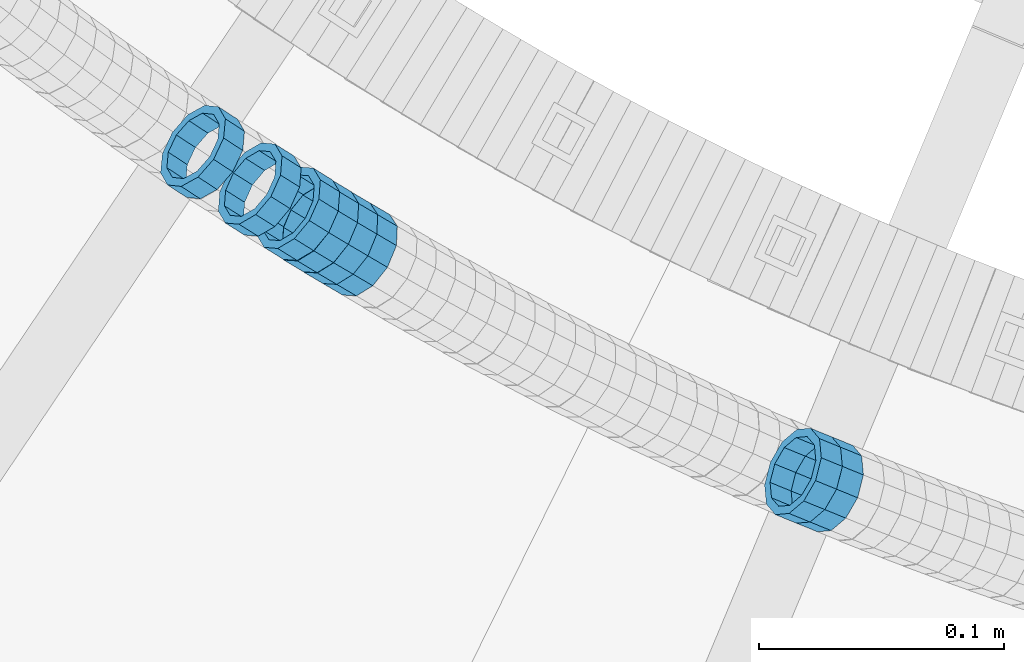
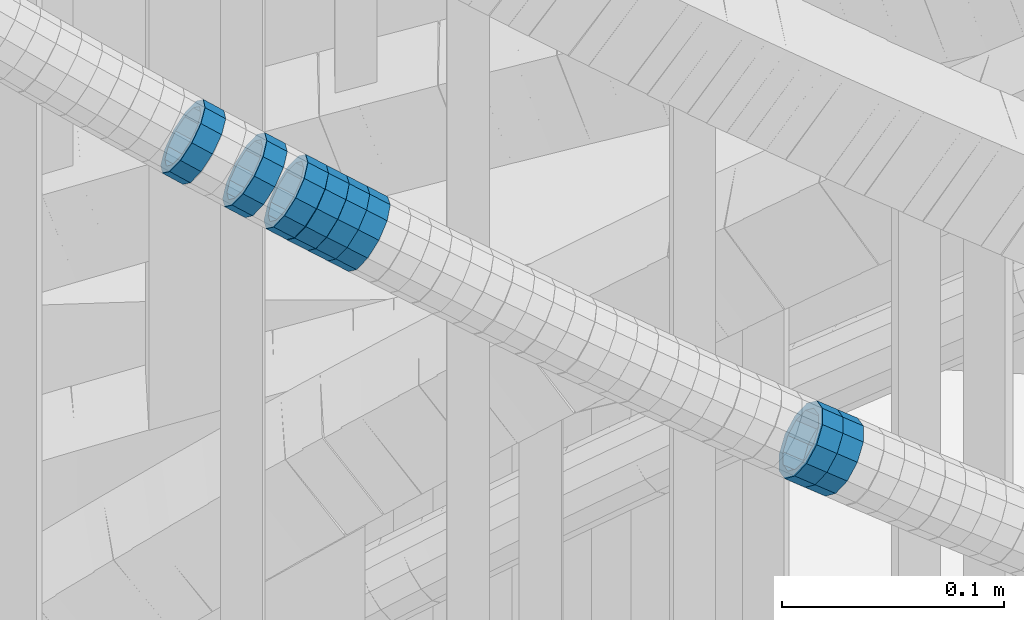
# One storey, part 693 of 975: 8 members.
"""IFC2X3 building model written with IfcOpenShell, lengths in millimetres."""

import ifcopenshell
import ifcopenshell.guid

model = None  # the IFC model being written
_history = None  # IfcOwnerHistory: only IFC2X3 demands one
_inside = {}  # id of a spatial element -> (the spatial element, [elements in it])
_under = {}  # id of a project, library or spatial element -> (it, [spatial elements below it])
_declared = {}  # id of a project -> (the project, [libraries it declares])
_typed = {}  # id of a type object -> (the type object, [elements of that type])
_made_of = {}  # id of a material, layer set ... -> (it, [elements and type objects made of it])


def new_model(schema):
    """Start an empty IFC model of exactly this schema.

    Asked for "IFC4X3", IfcOpenShell would pick the latest addendum, in which some entities
    have other attributes; the version numbers below select the first issue.
    IFC2X3 requires an IfcOwnerHistory on every rooted entity: one is made here for all.
    """
    global model, _history
    if schema == "IFC4X3":
        model = ifcopenshell.file(schema_version=(4, 3, 0, 0))
    else:
        model = ifcopenshell.file(schema=schema)
    _inside.clear()
    _under.clear()
    _declared.clear()
    _typed.clear()
    _made_of.clear()
    _history = None
    if model.schema == "IFC2X3":
        org = make("IfcOrganization", Name="unknown")
        user = make(
            "IfcPersonAndOrganization",
            ThePerson=make("IfcPerson", FamilyName="unknown"),
            TheOrganization=org,
        )
        app = make(
            "IfcApplication",
            ApplicationDeveloper=org,
            Version="unknown",
            ApplicationFullName="unknown",
            ApplicationIdentifier="unknown",
        )
        _history = make(
            "IfcOwnerHistory",
            OwningUser=user,
            OwningApplication=app,
            ChangeAction="ADDED",
            CreationDate=0,
        )
    return model


def make(cls, **values):
    """One entity of the class cls with the attributes given. An attribute that is None is left unset."""
    return model.create_entity(
        cls, **{name: value for name, value in values.items() if value is not None}
    )


def rooted(cls, **values):
    """An entity with a GlobalId (a new one), such as an element, a storey or a relation."""
    return make(cls, GlobalId=ifcopenshell.guid.new(), OwnerHistory=_history, **values)


def si_unit(unit_type, name, prefix=None):
    """IfcSIUnit, for example si_unit("LENGTHUNIT", "METRE", prefix="MILLI")."""
    return make("IfcSIUnit", UnitType=unit_type, Prefix=prefix, Name=name)


def assignment(units):
    """IfcUnitAssignment: the units of a project."""
    return None if units is None else make("IfcUnitAssignment", Units=units)


def point(xyz):
    """IfcCartesianPoint."""
    return None if xyz is None else make("IfcCartesianPoint", Coordinates=xyz)


def direction(xyz):
    """IfcDirection."""
    return None if xyz is None else make("IfcDirection", DirectionRatios=xyz)


def frame(location, z_axis=None, x_axis=None):
    """IfcAxis2Placement3D, a coordinate frame: its origin and axes. An axis left out is left unset."""
    return make(
        "IfcAxis2Placement3D",
        Location=point(location),
        Axis=direction(z_axis),
        RefDirection=direction(x_axis),
    )


def origin_with_axes():
    """The frame at (0, 0, 0) with the z axis (0, 0, 1) and the x axis (1, 0, 0) written out."""
    return frame((0.0, 0.0, 0.0), z_axis=(0.0, 0.0, 1.0), x_axis=(1.0, 0.0, 0.0))


def place(relative_to, where):
    """IfcLocalPlacement: puts the frame where relative to a parent placement (None: the world)."""
    return make(
        "IfcLocalPlacement", PlacementRelTo=relative_to, RelativePlacement=where
    )


def context(
    kind, dimensions, precision=None, world=None, true_north=None, identifier=None
):
    """IfcGeometricRepresentationContext, for example the 3D "Model" context."""
    return make(
        "IfcGeometricRepresentationContext",
        ContextIdentifier=identifier,
        ContextType=kind,
        CoordinateSpaceDimension=dimensions,
        Precision=precision,
        WorldCoordinateSystem=world,
        TrueNorth=true_north,
    )


def subcontext(parent, identifier, kind, view, scale=None):
    """IfcGeometricRepresentationSubContext, for example "Body" below "Model"."""
    return make(
        "IfcGeometricRepresentationSubContext",
        ContextIdentifier=identifier,
        ContextType=kind,
        ParentContext=parent,
        TargetScale=scale,
        TargetView=view,
    )


def project(units=None, contexts=None):
    """IfcProject with its units and contexts."""
    return rooted(
        "IfcProject",
        Name="project",
        RepresentationContexts=contexts,
        UnitsInContext=assignment(units),
    )


def spatial(cls, under=None, at=None, **own):
    """A site, building, storey or space (cls), placed at a placement, below another one or the project."""
    s = rooted(cls, ObjectPlacement=at, **own)
    if under is not None:
        _under.setdefault(under.id(), (under, []))[1].append(s)
    return s


def faces_of(points, faces, orient=None, outer=None):
    """IfcFace entities. A face is a list of loops; a loop is a list of indices into points, from 0.

    orient and outer hold one flag for each loop. By default every Orientation is true, the
    first loop of a face is its IfcFaceOuterBound and the others are IfcFaceBound.
    """
    made = []
    for i, loops in enumerate(faces):
        bounds = []
        for j, loop in enumerate(loops):
            is_outer = j == 0 if outer is None else outer[i][j]
            bounds.append(
                make(
                    "IfcFaceOuterBound" if is_outer else "IfcFaceBound",
                    Bound=make("IfcPolyLoop", Polygon=[points[k] for k in loop]),
                    Orientation=True if orient is None else orient[i][j],
                )
            )
        made.append(make("IfcFace", Bounds=bounds))
    return made


def faceted_brep(points, faces, orient=None, outer=None, voids=None):
    """IfcFacetedBrep: a solid bounded by flat faces; with voids (closed shells), ...WithVoids."""
    shared = [point(p) for p in points]
    hull = make("IfcClosedShell", CfsFaces=faces_of(shared, faces, orient, outer))
    if voids is None:
        return make("IfcFacetedBrep", Outer=hull)
    return make(
        "IfcFacetedBrepWithVoids",
        Outer=hull,
        Voids=[
            make(cls, CfsFaces=faces_of(shared, fs, o, b)) for cls, fs, o, b in voids
        ],
    )


def shape(context_of_items, identifier, shape_type, items):
    """IfcShapeRepresentation: the items that make up one representation, for example the "Body"."""
    return make(
        "IfcShapeRepresentation",
        ContextOfItems=context_of_items,
        RepresentationIdentifier=identifier,
        RepresentationType=shape_type,
        Items=items,
    )


def material(Name=None, Category=None):
    """IfcMaterial."""
    return make("IfcMaterial", Name=Name, Category=Category)


def made_of(thing, what):
    """Note that an element or type object is made of a material, layer set ...; save() writes the relation."""
    if what is not None:
        _made_of.setdefault(what.id(), (what, []))[1].append(thing)
    return thing


def type_object(cls, material=None, **own):
    """A type object (cls), such as IfcWallType, which elements share."""
    return made_of(rooted(cls, **own), material)


def element(
    cls,
    number,
    at=None,
    inside=None,
    cuts=None,
    type_object=None,
    material=None,
    context=None,
    identifier="Body",
    shape_type=None,
    held_by="IfcProductDefinitionShape",
    body=None,
    shapes=None,
    **own,
):
    """One element of the class cls, such as IfcWall. Its Tag is "e" and its number.

    at: its placement. inside: the storey or other place that contains it. cuts: it is an
    opening in that element (IfcRelVoidsElement). A single representation is given by context,
    identifier, shape_type and body (its items); several are given by shapes. held_by: the class
    of the entity that holds the representations. save() writes the other relations.
    """
    e = rooted(cls, Tag="e%d" % number, ObjectPlacement=at, **own)
    if body is not None:
        shapes = [shape(context, identifier, shape_type, body)]
    if shapes is not None:
        e.Representation = make(held_by, Representations=shapes)
    if inside is not None:
        _inside.setdefault(inside.id(), (inside, []))[1].append(e)
    if cuts is not None:
        rooted(
            "IfcRelVoidsElement", RelatingBuildingElement=cuts, RelatedOpeningElement=e
        )
    if type_object is not None:
        _typed.setdefault(type_object.id(), (type_object, []))[1].append(e)
    return made_of(e, material)


def aggregate(whole, parts):
    """IfcRelAggregates: a whole, such as a stair, and the parts it consists of."""
    return rooted("IfcRelAggregates", RelatingObject=whole, RelatedObjects=parts)


def save(model, path):
    """Write the relations noted so far, then the file.

    IfcRelAggregates (storeys below a building ...), IfcRelContainedInSpatialStructure (elements
    in a storey), IfcRelDefinesByType, IfcRelAssociatesMaterial and IfcRelDeclares: one each for
    every whole, place, type object, material and project.
    """
    for whole, parts in _under.values():
        aggregate(whole, parts)
    for where, things in _inside.values():
        rooted(
            "IfcRelContainedInSpatialStructure",
            RelatedElements=things,
            RelatingStructure=where,
        )
    for kind, things in _typed.values():
        rooted("IfcRelDefinesByType", RelatedObjects=things, RelatingType=kind)
    for what, things in _made_of.values():
        rooted("IfcRelAssociatesMaterial", RelatedObjects=things, RelatingMaterial=what)
    for by, libraries in _declared.values():
        rooted("IfcRelDeclares", RelatingContext=by, RelatedDefinitions=libraries)
    model.write(path)


model = new_model("IFC2X3")

# Units and contexts
model_context = context("Model", 3, precision=1e-05, world=origin_with_axes())
body_context = subcontext(model_context, "Body", "Model", "MODEL_VIEW")
ifc_project = project(units=[si_unit("LENGTHUNIT", "METRE", prefix="MILLI"), si_unit("AREAUNIT", "SQUARE_METRE"), si_unit("VOLUMEUNIT", "CUBIC_METRE"), si_unit("MASSUNIT", "GRAM", prefix="KILO"), si_unit("TIMEUNIT", "SECOND"), si_unit("PLANEANGLEUNIT", "RADIAN"), si_unit("SOLIDANGLEUNIT", "STERADIAN"), si_unit("THERMODYNAMICTEMPERATUREUNIT", "DEGREE_CELSIUS"), si_unit("LUMINOUSINTENSITYUNIT", "LUMEN")], contexts=[model_context])

# Site, building, storey
site_placement = place(None, origin_with_axes())
site = spatial("IfcSite", under=ifc_project, at=site_placement, CompositionType="ELEMENT")
building_placement = place(site_placement, origin_with_axes())
building = spatial("IfcBuilding", under=site, at=building_placement, Name="Undefined", CompositionType="ELEMENT")
storey_placement = place(building_placement, origin_with_axes())
storey = spatial("IfcBuildingStorey", under=building, at=storey_placement, Name="Undefined", CompositionType="ELEMENT", Elevation=0.0)

# Members
ifc_material = material()
member_type = type_object("IfcMemberType", PredefinedType="NOTDEFINED")
member_1_placement = place(storey_placement, frame((33980.090284049, 2130.72236019374, 4695.14638078626), z_axis=(-0.506549048880574, -0.862211146459025, 1.05085746326949e-10), x_axis=(-0.73111971628971, 0.429532833170209, 0.530061794210098)))
element("IfcMember", 1, at=member_1_placement, inside=storey, type_object=member_type, material=ifc_material, Name="WALL", context=body_context, shape_type="Brep", body=[
    faceted_brep([(-2.1246523829177e-07, -15.367000000002, 0.0), (-1.83998054126278e-07, -13.3082123799541, 7.68350000000009), (10.9448618081915, -13.3082123799541, 7.68349999999987), (10.944861808206, -15.3669999999875, -1.81898940354586e-12), (-1.06232619145885e-07, -7.68349999999919, 13.3082123799559), (10.9448618081733, -7.68350000000282, 13.3082123799568), (-3.63797880709171e-12, 3.63797880709171e-12, 15.3670000000002), (10.944861808166, -1.09139364212751e-11, 15.3670000000025), (1.06225343188271e-07, 7.68350000000646, 13.3082123799559), (10.9448618081624, 7.68349999998827, 13.3082123799586), (1.8399441614747e-07, 13.308212379965, 7.68350000000009), (10.9448618081697, 13.3082123799468, 7.68350000000214), (2.12461600312963e-07, 15.3670000000093, 0.0), (10.9448618081842, 15.3669999999984, 2.27373675443232e-13), (1.8399441614747e-07, 13.308212379965, -7.68350000000009), (10.9448618082024, 13.3082123799613, -7.68350000000123), (1.06225343188271e-07, 7.68350000000646, -13.3082123799559), (10.944861808217, 7.68350000001374, -13.3082123799586), (-3.63797880709171e-12, 3.63797880709171e-12, -15.3670000000002), (10.9448618082242, 1.45519152283669e-11, -15.3670000000036), (-1.06232619145885e-07, -7.68349999999919, -13.3082123799559), (10.9448618082279, -7.68349999997736, -13.30821237996), (-1.83998054126278e-07, -13.3082123799541, -7.68350000000009), (10.9448618082242, -13.3082123799322, -7.68350000000351), (-2.63386027654633e-07, -19.0500000000029, 0.0), (-2.28097633225843e-07, -16.4977839420972, -9.52499999999964), (10.9448618082242, -16.4977839420681, -9.52500000000418), (10.9448618082097, -19.0499999999847, -2.50111042987555e-12), (-1.31691194837913e-07, -9.52500000000146, -16.4977839420935), (10.9448618082351, -9.52499999997599, -16.4977839420985), (-3.63797880709171e-12, 3.63797880709171e-12, -19.0500000000002), (10.9448618082315, 2.5465851649642e-11, -19.050000000004), (1.31687556859106e-07, 9.52500000000509, -16.4977839420935), (10.9448618082242, 9.52500000001601, -16.4977839420967), (2.28097633225843e-07, 16.4977839421044, -9.52499999999964), (10.9448618082097, 16.4977839421008, -9.52500000000146), (2.63382389675826e-07, 19.0500000000138, 0.0), (10.9448618081842, 19.049999999992, 1.13686837721616e-12), (2.28097633225843e-07, 16.4977839421044, 9.52499999999964), (10.944861808166, 16.4977839420826, 9.52500000000259), (1.31687556859106e-07, 9.52500000000509, 16.4977839420935), (10.9448618081624, 9.52499999998327, 16.4977839420972), (-3.63797880709171e-12, 3.63797880709171e-12, 19.0500000000002), (10.9448618081587, -1.09139364212751e-11, 19.0500000000031), (-1.31691194837913e-07, -9.52500000000146, 16.4977839420935), (10.9448618081697, -9.52500000000873, 16.4977839420953), (-2.28097633225843e-07, -16.4977839420972, 9.52499999999964), (10.9448618081915, -16.4977839420899, 9.52499999999941)], [[[0, 1, 2, 3]], [[1, 4, 5, 2]], [[4, 6, 7, 5]], [[6, 8, 9, 7]], [[8, 10, 11, 9]], [[10, 12, 13, 11]], [[12, 14, 15, 13]], [[14, 16, 17, 15]], [[16, 18, 19, 17]], [[18, 20, 21, 19]], [[20, 22, 23, 21]], [[22, 0, 3, 23]], [[24, 25, 26, 27]], [[25, 28, 29, 26]], [[28, 30, 31, 29]], [[30, 32, 33, 31]], [[32, 34, 35, 33]], [[34, 36, 37, 35]], [[36, 38, 39, 37]], [[38, 40, 41, 39]], [[40, 42, 43, 41]], [[42, 44, 45, 43]], [[44, 46, 47, 45]], [[46, 24, 27, 47]], [[29, 31, 33, 35, 37, 39, 41, 43, 45, 47, 27, 26], [5, 7, 9, 11, 13, 15, 17, 19, 21, 23, 3, 2]], [[46, 44, 42, 40, 38, 36, 34, 32, 30, 28, 25, 24], [22, 20, 18, 16, 14, 12, 10, 8, 6, 4, 1, 0]]]),
])
member_2_placement = place(storey_placement, frame((33917.171861145, 2170.1158835901, 4740.92648604226), z_axis=(-0.547249362822599, -0.836969614078229, -1.1905467545148e-10), x_axis=(-0.710590014914603, 0.464616547944192, 0.528387446936513)))
element("IfcMember", 2, at=member_2_placement, inside=storey, type_object=member_type, material=ifc_material, Name="WALL", context=body_context, shape_type="Brep", body=[
    faceted_brep([(-2.1246523829177e-07, -15.367000000002, 0.0), (-1.83998054126278e-07, -13.3082123799541, 7.68350000000009), (10.9799817850508, -13.3082123799686, 7.6835000000051), (10.9799817850435, -15.3670000000202, 5.45696821063757e-12), (-1.06232619145885e-07, -7.68349999999919, 13.3082123799559), (10.9799817850653, -7.68350000000282, 13.3082123799577), (-3.63797880709171e-12, 3.63797880709171e-12, 15.3670000000002), (10.9799817850871, 1.45519152283669e-11, 15.3669999999984), (1.06225343188271e-07, 7.68350000000646, 13.3082123799559), (10.9799817851053, 7.68350000002465, 13.3082123799504), (1.8399441614747e-07, 13.308212379965, 7.68350000000009), (10.9799817851163, 13.3082123799904, 7.68349999999191), (2.12461600312963e-07, 15.3670000000093, 0.0), (10.9799817851199, 15.3670000000347, -9.09494701772928e-12), (1.8399441614747e-07, 13.308212379965, -7.68350000000009), (10.9799817851126, 13.3082123799832, -7.68350000000783), (1.06225343188271e-07, 7.68350000000646, -13.3082123799559), (10.9799817850981, 7.68350000001737, -13.3082123799613), (-3.63797880709171e-12, 3.63797880709171e-12, -15.3670000000002), (10.9799817850799, 3.63797880709171e-12, -15.367000000002), (-1.06232619145885e-07, -7.68349999999919, -13.3082123799559), (10.9799817850653, -7.68350000000646, -13.308212379955), (-1.83998054126278e-07, -13.3082123799541, -7.68350000000009), (10.9799817850508, -13.3082123799722, -7.68349999999509), (-2.63386027654633e-07, -19.0500000000029, 0.0), (-2.28097633225843e-07, -16.4977839420972, -9.52499999999964), (10.9799817850399, -16.4977839421153, -9.52499999999418), (10.9799817850362, -19.0500000000247, 6.3664629124105e-12), (-1.31691194837913e-07, -9.52500000000146, -16.4977839420935), (10.979981785058, -9.52500000001237, -16.4977839420912), (-3.63797880709171e-12, 3.63797880709171e-12, -19.0500000000002), (10.9799817850799, 0.0, -19.050000000002), (1.31687556859106e-07, 9.52500000000509, -16.4977839420935), (10.9799817851017, 9.52500000001965, -16.4977839420999), (2.28097633225843e-07, 16.4977839421044, -9.52499999999964), (10.9799817851235, 16.4977839421299, -9.5250000000101), (2.63382389675826e-07, 19.0500000000138, 0.0), (10.9799817851308, 19.0500000000393, -1.09139364212751e-11), (2.28097633225843e-07, 16.4977839421044, 9.52499999999964), (10.9799817851235, 16.4977839421335, 9.52499999999054), (1.31687556859106e-07, 9.52500000000509, 16.4977839420935), (10.979981785109, 9.52500000003056, 16.4977839420881), (-3.63797880709171e-12, 3.63797880709171e-12, 19.0500000000002), (10.9799817850871, 1.45519152283669e-11, 19.0499999999984), (-1.31691194837913e-07, -9.52500000000146, 16.4977839420935), (10.9799817850617, -9.52500000000509, 16.4977839420962), (-2.28097633225843e-07, -16.4977839420972, 9.52499999999964), (10.9799817850435, -16.4977839421117, 9.52500000000691)], [[[0, 1, 2, 3]], [[1, 4, 5, 2]], [[4, 6, 7, 5]], [[6, 8, 9, 7]], [[8, 10, 11, 9]], [[10, 12, 13, 11]], [[12, 14, 15, 13]], [[14, 16, 17, 15]], [[16, 18, 19, 17]], [[18, 20, 21, 19]], [[20, 22, 23, 21]], [[22, 0, 3, 23]], [[24, 25, 26, 27]], [[25, 28, 29, 26]], [[28, 30, 31, 29]], [[30, 32, 33, 31]], [[32, 34, 35, 33]], [[34, 36, 37, 35]], [[36, 38, 39, 37]], [[38, 40, 41, 39]], [[40, 42, 43, 41]], [[42, 44, 45, 43]], [[44, 46, 47, 45]], [[46, 24, 27, 47]], [[29, 31, 33, 35, 37, 39, 41, 43, 45, 47, 27, 26], [5, 7, 9, 11, 13, 15, 17, 19, 21, 23, 3, 2]], [[46, 44, 42, 40, 38, 36, 34, 32, 30, 28, 25, 24], [22, 20, 18, 16, 14, 12, 10, 8, 6, 4, 1, 0]]]),
])
member_3_placement = place(storey_placement, frame((34171.5652875128, 2035.26432656973, 4563.16514397444), z_axis=(-0.376954751079618, -0.926231674927231, 6.32007868262007e-11), x_axis=(-0.78935632201243, 0.321249666005062, 0.523178028008292)))
element("IfcMember", 3, at=member_3_placement, inside=storey, type_object=member_type, material=ifc_material, Name="WALL", context=body_context, shape_type="Brep", body=[
    faceted_brep([(-2.1246523829177e-07, -15.367000000002, 0.0), (-1.83998054126278e-07, -13.3082123799541, 7.68350000000009), (10.8908218239267, -13.3082123799468, 7.68349999999828), (10.8908218239521, -15.3669999999729, -6.3664629124105e-12), (-1.06232619145885e-07, -7.68349999999919, 13.3082123799559), (10.8908218238939, -7.6835000000101, 13.3082123799586), (-3.63797880709171e-12, 3.63797880709171e-12, 15.3670000000002), (10.8908218238757, -2.18278728425503e-11, 15.3670000000075), (1.06225343188271e-07, 7.68350000000646, 13.3082123799559), (10.8908218238612, 7.68349999996644, 13.308212379965), (1.8399441614747e-07, 13.308212379965, 7.68350000000009), (10.8908218238612, 13.308212379925, 7.68350000000919), (2.12461600312963e-07, 15.3670000000093, 0.0), (10.8908218238794, 15.3669999999802, 5.45696821063757e-12), (1.8399441614747e-07, 13.308212379965, -7.68350000000009), (10.8908218239012, 13.3082123799541, -7.68349999999828), (1.06225343188271e-07, 7.68350000000646, -13.3082123799559), (10.8908218239339, 7.68350000001737, -13.30821237996), (-3.63797880709171e-12, 3.63797880709171e-12, -15.3670000000002), (10.8908218239558, 3.27418092638254e-11, -15.3670000000075), (-1.06232619145885e-07, -7.68349999999919, -13.3082123799559), (10.890821823974, -7.68349999996281, -13.308212379965), (-1.83998054126278e-07, -13.3082123799541, -7.68350000000009), (10.8908218239667, -13.3082123799177, -7.68350000000919), (-2.63386027654633e-07, -19.0500000000029, 0.0), (-2.28097633225843e-07, -16.4977839420972, -9.52499999999964), (10.8908218239812, -16.4977839420499, -9.52500000001055), (10.8908218239594, -19.0499999999665, -7.73070496506989e-12), (-1.31691194837913e-07, -9.52500000000146, -16.4977839420935), (10.8908218239812, -9.52499999994689, -16.4977839421063), (-3.63797880709171e-12, 3.63797880709171e-12, -19.0500000000002), (10.8908218239703, 3.63797880709171e-11, -19.0500000000093), (1.31687556859106e-07, 9.52500000000509, -16.4977839420935), (10.8908218239412, 9.52500000002328, -16.4977839420981), (2.28097633225843e-07, 16.4977839421044, -9.52499999999964), (10.8908218239048, 16.4977839420899, -9.52499999999873), (2.63382389675826e-07, 19.0500000000138, 0.0), (10.8908218238685, 19.0499999999774, 6.82121026329696e-12), (2.28097633225843e-07, 16.4977839421044, 9.52499999999964), (10.8908218238539, 16.4977839420535, 9.525000000011), (1.31687556859106e-07, 9.52500000000509, 16.4977839420935), (10.8908218238466, 9.52499999996144, 16.4977839421058), (-3.63797880709171e-12, 3.63797880709171e-12, 19.0500000000002), (10.8908218238648, -3.27418092638254e-11, 19.0500000000097), (-1.31691194837913e-07, -9.52500000000146, 16.4977839420935), (10.8908218238939, -9.52500000000873, 16.4977839420972), (-2.28097633225843e-07, -16.4977839420972, 9.52499999999964), (10.8908218239267, -16.4977839420826, 9.52499999999873)], [[[0, 1, 2, 3]], [[1, 4, 5, 2]], [[4, 6, 7, 5]], [[6, 8, 9, 7]], [[8, 10, 11, 9]], [[10, 12, 13, 11]], [[12, 14, 15, 13]], [[14, 16, 17, 15]], [[16, 18, 19, 17]], [[18, 20, 21, 19]], [[20, 22, 23, 21]], [[22, 0, 3, 23]], [[24, 25, 26, 27]], [[25, 28, 29, 26]], [[28, 30, 31, 29]], [[30, 32, 33, 31]], [[32, 34, 35, 33]], [[34, 36, 37, 35]], [[36, 38, 39, 37]], [[38, 40, 41, 39]], [[40, 42, 43, 41]], [[42, 44, 45, 43]], [[44, 46, 47, 45]], [[46, 24, 27, 47]], [[29, 31, 33, 35, 37, 39, 41, 43, 45, 47, 27, 26], [5, 7, 9, 11, 13, 15, 17, 19, 21, 23, 3, 2]], [[46, 44, 42, 40, 38, 36, 34, 32, 30, 28, 25, 24], [22, 20, 18, 16, 14, 12, 10, 8, 6, 4, 1, 0]]]),
])
member_4_placement = place(storey_placement, frame((34162.9652875128, 2038.76432656973, 4568.86514397447), z_axis=(-0.376954751079618, -0.926231674927231, 6.32007868262007e-11), x_axis=(-0.78935632201243, 0.321249666005062, 0.523178028008292)))
element("IfcMember", 4, at=member_4_placement, inside=storey, type_object=member_type, material=ifc_material, Name="WALL", context=body_context, shape_type="Brep", body=[
    faceted_brep([(-2.1246523829177e-07, -15.367000000002, 0.0), (-1.83998054126278e-07, -13.3082123799541, 7.68350000000009), (10.8908218239267, -13.3082123799468, 7.68349999999828), (10.8908218239521, -15.3669999999729, -6.3664629124105e-12), (-1.06232619145885e-07, -7.68349999999919, 13.3082123799559), (10.8908218238939, -7.6835000000101, 13.3082123799586), (-3.63797880709171e-12, 3.63797880709171e-12, 15.3670000000002), (10.8908218238757, -2.18278728425503e-11, 15.3670000000075), (1.06225343188271e-07, 7.68350000000646, 13.3082123799559), (10.8908218238612, 7.68349999996644, 13.308212379965), (1.8399441614747e-07, 13.308212379965, 7.68350000000009), (10.8908218238612, 13.308212379925, 7.68350000000919), (2.12461600312963e-07, 15.3670000000093, 0.0), (10.8908218238794, 15.3669999999802, 5.45696821063757e-12), (1.8399441614747e-07, 13.308212379965, -7.68350000000009), (10.8908218239012, 13.3082123799541, -7.68349999999828), (1.06225343188271e-07, 7.68350000000646, -13.3082123799559), (10.8908218239339, 7.68350000001737, -13.30821237996), (-3.63797880709171e-12, 3.63797880709171e-12, -15.3670000000002), (10.8908218239558, 3.27418092638254e-11, -15.3670000000075), (-1.06232619145885e-07, -7.68349999999919, -13.3082123799559), (10.890821823974, -7.68349999996281, -13.308212379965), (-1.83998054126278e-07, -13.3082123799541, -7.68350000000009), (10.8908218239667, -13.3082123799177, -7.68350000000919), (-2.63386027654633e-07, -19.0500000000029, 0.0), (-2.28097633225843e-07, -16.4977839420972, -9.52499999999964), (10.8908218239812, -16.4977839420499, -9.52500000001055), (10.8908218239594, -19.0499999999665, -7.73070496506989e-12), (-1.31691194837913e-07, -9.52500000000146, -16.4977839420935), (10.8908218239812, -9.52499999994689, -16.4977839421063), (-3.63797880709171e-12, 3.63797880709171e-12, -19.0500000000002), (10.8908218239703, 3.63797880709171e-11, -19.0500000000093), (1.31687556859106e-07, 9.52500000000509, -16.4977839420935), (10.8908218239412, 9.52500000002328, -16.4977839420981), (2.28097633225843e-07, 16.4977839421044, -9.52499999999964), (10.8908218239048, 16.4977839420899, -9.52499999999873), (2.63382389675826e-07, 19.0500000000138, 0.0), (10.8908218238685, 19.0499999999774, 6.82121026329696e-12), (2.28097633225843e-07, 16.4977839421044, 9.52499999999964), (10.8908218238539, 16.4977839420535, 9.525000000011), (1.31687556859106e-07, 9.52500000000509, 16.4977839420935), (10.8908218238466, 9.52499999996144, 16.4977839421058), (-3.63797880709171e-12, 3.63797880709171e-12, 19.0500000000002), (10.8908218238648, -3.27418092638254e-11, 19.0500000000097), (-1.31691194837913e-07, -9.52500000000146, 16.4977839420935), (10.8908218238939, -9.52500000000873, 16.4977839420972), (-2.28097633225843e-07, -16.4977839420972, 9.52499999999964), (10.8908218239267, -16.4977839420826, 9.52499999999873)], [[[0, 1, 2, 3]], [[1, 4, 5, 2]], [[4, 6, 7, 5]], [[6, 8, 9, 7]], [[8, 10, 11, 9]], [[10, 12, 13, 11]], [[12, 14, 15, 13]], [[14, 16, 17, 15]], [[16, 18, 19, 17]], [[18, 20, 21, 19]], [[20, 22, 23, 21]], [[22, 0, 3, 23]], [[24, 25, 26, 27]], [[25, 28, 29, 26]], [[28, 30, 31, 29]], [[30, 32, 33, 31]], [[32, 34, 35, 33]], [[34, 36, 37, 35]], [[36, 38, 39, 37]], [[38, 40, 41, 39]], [[40, 42, 43, 41]], [[42, 44, 45, 43]], [[44, 46, 47, 45]], [[46, 24, 27, 47]], [[29, 31, 33, 35, 37, 39, 41, 43, 45, 47, 27, 26], [5, 7, 9, 11, 13, 15, 17, 19, 21, 23, 3, 2]], [[46, 44, 42, 40, 38, 36, 34, 32, 30, 28, 25, 24], [22, 20, 18, 16, 14, 12, 10, 8, 6, 4, 1, 0]]]),
])
member_5_placement = place(storey_placement, frame((33972.1990037745, 2135.35848735497, 4700.86824012306), z_axis=(-0.506549048880574, -0.862211146459025, 1.05085746326949e-10), x_axis=(-0.734656395984671, 0.431610632990997, 0.523442681989084)))
element("IfcMember", 5, at=member_5_placement, inside=storey, type_object=member_type, material=ifc_material, Name="WALL", context=body_context, shape_type="Brep", body=[
    faceted_brep([(-2.1246523829177e-07, -15.367000000002, 0.0), (-1.83998054126278e-07, -13.3082123799541, 7.68350000000009), (10.8908218239267, -13.3082123799468, 7.68349999999828), (10.8908218239521, -15.3669999999729, -6.3664629124105e-12), (-1.06232619145885e-07, -7.68349999999919, 13.3082123799559), (10.8908218238939, -7.6835000000101, 13.3082123799586), (-3.63797880709171e-12, 3.63797880709171e-12, 15.3670000000002), (10.8908218238757, -2.18278728425503e-11, 15.3670000000075), (1.06225343188271e-07, 7.68350000000646, 13.3082123799559), (10.8908218238612, 7.68349999996644, 13.308212379965), (1.8399441614747e-07, 13.308212379965, 7.68350000000009), (10.8908218238612, 13.308212379925, 7.68350000000919), (2.12461600312963e-07, 15.3670000000093, 0.0), (10.8908218238794, 15.3669999999802, 5.45696821063757e-12), (1.8399441614747e-07, 13.308212379965, -7.68350000000009), (10.8908218239012, 13.3082123799541, -7.68349999999828), (1.06225343188271e-07, 7.68350000000646, -13.3082123799559), (10.8908218239339, 7.68350000001737, -13.30821237996), (-3.63797880709171e-12, 3.63797880709171e-12, -15.3670000000002), (10.8908218239558, 3.27418092638254e-11, -15.3670000000075), (-1.06232619145885e-07, -7.68349999999919, -13.3082123799559), (10.890821823974, -7.68349999996281, -13.308212379965), (-1.83998054126278e-07, -13.3082123799541, -7.68350000000009), (10.8908218239667, -13.3082123799177, -7.68350000000919), (-2.63386027654633e-07, -19.0500000000029, 0.0), (-2.28097633225843e-07, -16.4977839420972, -9.52499999999964), (10.8908218239812, -16.4977839420499, -9.52500000001055), (10.8908218239594, -19.0499999999665, -7.73070496506989e-12), (-1.31691194837913e-07, -9.52500000000146, -16.4977839420935), (10.8908218239812, -9.52499999994689, -16.4977839421063), (-3.63797880709171e-12, 3.63797880709171e-12, -19.0500000000002), (10.8908218239703, 3.63797880709171e-11, -19.0500000000093), (1.31687556859106e-07, 9.52500000000509, -16.4977839420935), (10.8908218239412, 9.52500000002328, -16.4977839420981), (2.28097633225843e-07, 16.4977839421044, -9.52499999999964), (10.8908218239048, 16.4977839420899, -9.52499999999873), (2.63382389675826e-07, 19.0500000000138, 0.0), (10.8908218238685, 19.0499999999774, 6.82121026329696e-12), (2.28097633225843e-07, 16.4977839421044, 9.52499999999964), (10.8908218238539, 16.4977839420535, 9.525000000011), (1.31687556859106e-07, 9.52500000000509, 16.4977839420935), (10.8908218238466, 9.52499999996144, 16.4977839421058), (-3.63797880709171e-12, 3.63797880709171e-12, 19.0500000000002), (10.8908218238648, -3.27418092638254e-11, 19.0500000000097), (-1.31691194837913e-07, -9.52500000000146, 16.4977839420935), (10.8908218238939, -9.52500000000873, 16.4977839420972), (-2.28097633225843e-07, -16.4977839420972, 9.52499999999964), (10.8908218239267, -16.4977839420826, 9.52499999999873)], [[[0, 1, 2, 3]], [[1, 4, 5, 2]], [[4, 6, 7, 5]], [[6, 8, 9, 7]], [[8, 10, 11, 9]], [[10, 12, 13, 11]], [[12, 14, 15, 13]], [[14, 16, 17, 15]], [[16, 18, 19, 17]], [[18, 20, 21, 19]], [[20, 22, 23, 21]], [[22, 0, 3, 23]], [[24, 25, 26, 27]], [[25, 28, 29, 26]], [[28, 30, 31, 29]], [[30, 32, 33, 31]], [[32, 34, 35, 33]], [[34, 36, 37, 35]], [[36, 38, 39, 37]], [[38, 40, 41, 39]], [[40, 42, 43, 41]], [[42, 44, 45, 43]], [[44, 46, 47, 45]], [[46, 24, 27, 47]], [[29, 31, 33, 35, 37, 39, 41, 43, 45, 47, 27, 26], [5, 7, 9, 11, 13, 15, 17, 19, 21, 23, 3, 2]], [[46, 44, 42, 40, 38, 36, 34, 32, 30, 28, 25, 24], [22, 20, 18, 16, 14, 12, 10, 8, 6, 4, 1, 0]]]),
])
member_6_placement = place(storey_placement, frame((33964.2800987496, 2140.1173004961, 4706.54391505818), z_axis=(-0.514495755433062, -0.857492925709223, 3.18282218358946e-10), x_axis=(-0.731731122651384, 0.439038673790773, 0.521358424751518)))
element("IfcMember", 6, at=member_6_placement, inside=storey, type_object=member_type, material=ifc_material, Name="WALL", context=body_context, shape_type="Brep", body=[
    faceted_brep([(-2.1246523829177e-07, -15.367000000002, 0.0), (-1.83998054126278e-07, -13.3082123799541, 7.68350000000009), (10.9334349588862, -13.3082123799722, 7.68350000000555), (10.9334349588862, -15.3670000000166, 5.45696821063757e-12), (-1.06232619145885e-07, -7.68349999999919, 13.3082123799559), (10.9334349588826, -7.68350000001737, 13.3082123799609), (-3.63797880709171e-12, 3.63797880709171e-12, 15.3670000000002), (10.9334349588862, -1.45519152283669e-11, 15.3670000000043), (1.06225343188271e-07, 7.68350000000646, 13.3082123799559), (10.9334349588898, 7.68349999998827, 13.3082123799591), (1.8399441614747e-07, 13.308212379965, 7.68350000000009), (10.9334349588898, 13.3082123799395, 7.68350000000419), (2.12461600312963e-07, 15.3670000000093, 0.0), (10.9334349588971, 15.3669999999911, 3.63797880709171e-12), (1.8399441614747e-07, 13.308212379965, -7.68350000000009), (10.9334349588935, 13.3082123799431, -7.683499999996), (1.06225343188271e-07, 7.68350000000646, -13.3082123799559), (10.9334349588971, 7.68349999998827, -13.3082123799518), (-3.63797880709171e-12, 3.63797880709171e-12, -15.3670000000002), (10.9334349588971, -1.45519152283669e-11, -15.3669999999961), (-1.06232619145885e-07, -7.68349999999919, -13.3082123799559), (10.9334349588935, -7.68350000001737, -13.3082123799509), (-1.83998054126278e-07, -13.3082123799541, -7.68350000000009), (10.9334349588898, -13.3082123799686, -7.68349999999464), (-2.63386027654633e-07, -19.0500000000029, 0.0), (-2.28097633225843e-07, -16.4977839420972, -9.52499999999964), (10.9334349588898, -16.4977839421117, -9.52499999999372), (10.9334349588898, -19.0500000000211, 5.45696821063757e-12), (-1.31691194837913e-07, -9.52500000000146, -16.4977839420935), (10.9334349588971, -9.52500000001237, -16.4977839420885), (-3.63797880709171e-12, 3.63797880709171e-12, -19.0500000000002), (10.9334349588971, -1.09139364212751e-11, -19.0499999999961), (1.31687556859106e-07, 9.52500000000509, -16.4977839420935), (10.9334349589008, 9.52499999999054, -16.4977839420894), (2.28097633225843e-07, 16.4977839421044, -9.52499999999964), (10.9334349589008, 16.4977839420826, -9.52499999999645), (2.63382389675826e-07, 19.0500000000138, 0.0), (10.9334349588898, 19.0499999999884, 3.18323145620525e-12), (2.28097633225843e-07, 16.4977839421044, 9.52499999999964), (10.9334349588935, 16.497783942079, 9.52500000000282), (1.31687556859106e-07, 9.52500000000509, 16.4977839420935), (10.9334349588826, 9.52499999998327, 16.4977839420976), (-3.63797880709171e-12, 3.63797880709171e-12, 19.0500000000002), (10.9334349588826, -1.81898940354586e-11, 19.0500000000043), (-1.31691194837913e-07, -9.52500000000146, 16.4977839420935), (10.9334349588826, -9.52500000001965, 16.4977839420994), (-2.28097633225843e-07, -16.4977839420972, 9.52499999999964), (10.9334349588826, -16.4977839421117, 9.52500000000646)], [[[0, 1, 2, 3]], [[1, 4, 5, 2]], [[4, 6, 7, 5]], [[6, 8, 9, 7]], [[8, 10, 11, 9]], [[10, 12, 13, 11]], [[12, 14, 15, 13]], [[14, 16, 17, 15]], [[16, 18, 19, 17]], [[18, 20, 21, 19]], [[20, 22, 23, 21]], [[22, 0, 3, 23]], [[24, 25, 26, 27]], [[25, 28, 29, 26]], [[28, 30, 31, 29]], [[30, 32, 33, 31]], [[32, 34, 35, 33]], [[34, 36, 37, 35]], [[36, 38, 39, 37]], [[38, 40, 41, 39]], [[40, 42, 43, 41]], [[42, 44, 45, 43]], [[44, 46, 47, 45]], [[46, 24, 27, 47]], [[29, 31, 33, 35, 37, 39, 41, 43, 45, 47, 27, 26], [5, 7, 9, 11, 13, 15, 17, 19, 21, 23, 3, 2]], [[46, 44, 42, 40, 38, 36, 34, 32, 30, 28, 25, 24], [22, 20, 18, 16, 14, 12, 10, 8, 6, 4, 1, 0]]]),
])
member_7_placement = place(storey_placement, frame((33956.3344660692, 2145.05606537621, 4712.25974216649), z_axis=(-0.527095063985726, -0.849806327066281, -2.88591763819568e-11), x_axis=(-0.724465822135536, 0.44935221908407, 0.522715846097767)))
element("IfcMember", 7, at=member_7_placement, inside=storey, type_object=member_type, material=ifc_material, Name="WALL", context=body_context, shape_type="Brep", body=[
    faceted_brep([(-2.1246523829177e-07, -15.367000000002, 0.0), (-1.83998054126278e-07, -13.3082123799541, 7.68350000000009), (10.9004587059244, -13.3082123799686, 7.68350000000282), (10.9004587059426, -15.3670000000093, 9.09494701772928e-13), (-1.06232619145885e-07, -7.68349999999919, 13.3082123799559), (10.9004587059244, -7.68350000001737, 13.3082123799586), (-3.63797880709171e-12, 3.63797880709171e-12, 15.3670000000002), (10.9004587059353, -1.45519152283669e-11, 15.3670000000029), (1.06225343188271e-07, 7.68350000000646, 13.3082123799559), (10.9004587059571, 7.68349999999555, 13.308212379955), (1.8399441614747e-07, 13.308212379965, 7.68350000000009), (10.9004587059753, 13.308212379965, 7.68349999999691), (2.12461600312963e-07, 15.3670000000093, 0.0), (10.9004587059935, 15.3670000000202, -5.45696821063757e-12), (1.8399441614747e-07, 13.308212379965, -7.68350000000009), (10.9004587060081, 13.3082123799832, -7.68350000000737), (1.06225343188271e-07, 7.68350000000646, -13.3082123799559), (10.9004587060081, 7.68350000002829, -13.3082123799632), (-3.63797880709171e-12, 3.63797880709171e-12, -15.3670000000002), (10.9004587060008, 2.91038304567337e-11, -15.3670000000075), (-1.06232619145885e-07, -7.68349999999919, -13.3082123799559), (10.900458705979, -7.683499999981, -13.3082123799595), (-1.83998054126278e-07, -13.3082123799541, -7.68350000000009), (10.9004587059608, -13.3082123799504, -7.68350000000191), (-2.63386027654633e-07, -19.0500000000029, 0.0), (-2.28097633225843e-07, -16.4977839420972, -9.52499999999964), (10.9004587059499, -16.4977839420899, -9.525000000001), (10.9004587059317, -19.0500000000102, 1.81898940354586e-12), (-1.31691194837913e-07, -9.52500000000146, -16.4977839420935), (10.9004587059826, -9.52499999997963, -16.497783942099), (-3.63797880709171e-12, 3.63797880709171e-12, -19.0500000000002), (10.9004587060008, 2.91038304567337e-11, -19.0500000000084), (1.31687556859106e-07, 9.52500000000509, -16.4977839420935), (10.900458706019, 9.52500000003783, -16.4977839421026), (2.28097633225843e-07, 16.4977839421044, -9.52499999999964), (10.900458706019, 16.4977839421263, -9.52500000000873), (2.63382389675826e-07, 19.0500000000138, 0.0), (10.9004587060044, 19.0500000000247, -6.82121026329696e-12), (2.28097633225843e-07, 16.4977839421044, 9.52499999999964), (10.9004587059826, 16.4977839421044, 9.52499999999736), (1.31687556859106e-07, 9.52500000000509, 16.4977839420935), (10.9004587059571, 9.52499999999418, 16.497783942094), (-3.63797880709171e-12, 3.63797880709171e-12, 19.0500000000002), (10.900458705928, -2.18278728425503e-11, 19.0500000000038), (-1.31691194837913e-07, -9.52500000000146, 16.4977839420935), (10.9004587059135, -9.52500000002328, 16.4977839420981), (-2.28097633225843e-07, -16.4977839420972, 9.52499999999964), (10.9004587059171, -16.4977839421153, 9.52500000000373)], [[[0, 1, 2, 3]], [[1, 4, 5, 2]], [[4, 6, 7, 5]], [[6, 8, 9, 7]], [[8, 10, 11, 9]], [[10, 12, 13, 11]], [[12, 14, 15, 13]], [[14, 16, 17, 15]], [[16, 18, 19, 17]], [[18, 20, 21, 19]], [[20, 22, 23, 21]], [[22, 0, 3, 23]], [[24, 25, 26, 27]], [[25, 28, 29, 26]], [[28, 30, 31, 29]], [[30, 32, 33, 31]], [[32, 34, 35, 33]], [[34, 36, 37, 35]], [[36, 38, 39, 37]], [[38, 40, 41, 39]], [[40, 42, 43, 41]], [[42, 44, 45, 43]], [[44, 46, 47, 45]], [[46, 24, 27, 47]], [[29, 31, 33, 35, 37, 39, 41, 43, 45, 47, 27, 26], [5, 7, 9, 11, 13, 15, 17, 19, 21, 23, 3, 2]], [[46, 44, 42, 40, 38, 36, 34, 32, 30, 28, 25, 24], [22, 20, 18, 16, 14, 12, 10, 8, 6, 4, 1, 0]]]),
])
member_8_placement = place(storey_placement, frame((33940.5084164253, 2154.93972058777, 4723.80063988947), z_axis=(-0.531949196091613, -0.846776270792638, 1.16259798232932e-10), x_axis=(-0.720064766075555, 0.452348379047531, 0.526201175055346)))
element("IfcMember", 8, at=member_8_placement, inside=storey, type_object=member_type, material=ifc_material, Name="WALL", context=body_context, shape_type="Brep", body=[
    faceted_brep([(-2.1246523829177e-07, -15.367000000002, 0.0), (-1.83998054126278e-07, -13.3082123799541, 7.68350000000009), (10.8323589305219, -13.308212379965, 7.68349999999373), (10.8323589305146, -15.3670000000129, -7.27595761418343e-12), (-1.06232619145885e-07, -7.68349999999919, 13.3082123799559), (10.8323589305437, -7.68349999999919, 13.3082123799531), (-3.63797880709171e-12, 3.63797880709171e-12, 15.3670000000002), (10.8323589305655, 7.27595761418343e-12, 15.367000000002), (1.06225343188271e-07, 7.68350000000646, 13.3082123799559), (10.8323589305764, 7.6835000000101, 13.3082123799604), (1.8399441614747e-07, 13.308212379965, 7.68350000000009), (10.8323589305837, 13.3082123799722, 7.68350000000646), (2.12461600312963e-07, 15.3670000000093, 0.0), (10.8323589305801, 15.3670000000202, 6.3664629124105e-12), (1.8399441614747e-07, 13.308212379965, -7.68350000000009), (10.8323589305692, 13.3082123799722, -7.68349999999555), (1.06225343188271e-07, 7.68350000000646, -13.3082123799559), (10.832358930551, 7.68350000000646, -13.3082123799541), (-3.63797880709171e-12, 3.63797880709171e-12, -15.3670000000002), (10.8323589305328, 0.0, -15.3670000000029), (-1.06232619145885e-07, -7.68349999999919, -13.3082123799559), (10.8323589305182, -7.68350000000646, -13.3082123799604), (-1.83998054126278e-07, -13.3082123799541, -7.68350000000009), (10.8323589305146, -13.3082123799686, -7.68350000000737), (-2.63386027654633e-07, -19.0500000000029, 0.0), (-2.28097633225843e-07, -16.4977839420972, -9.52499999999964), (10.8323589305, -16.4977839421117, -9.52500000000873), (10.832358930511, -19.0500000000102, -9.09494701772928e-12), (-1.31691194837913e-07, -9.52500000000146, -16.4977839420935), (10.8323589305146, -9.52500000000873, -16.4977839420999), (-3.63797880709171e-12, 3.63797880709171e-12, -19.0500000000002), (10.8323589305328, 3.63797880709171e-12, -19.0500000000029), (1.31687556859106e-07, 9.52500000000509, -16.4977839420935), (10.8323589305546, 9.52500000000873, -16.4977839420917), (2.28097633225843e-07, 16.4977839421044, -9.52499999999964), (10.8323589305764, 16.4977839421117, -9.52499999999327), (2.63382389675826e-07, 19.0500000000138, 0.0), (10.8323589305874, 19.0500000000211, 8.18545231595635e-12), (2.28097633225843e-07, 16.4977839421044, 9.52499999999964), (10.832358930591, 16.4977839421153, 9.52500000000873), (1.31687556859106e-07, 9.52500000000509, 16.4977839420935), (10.8323589305837, 9.52500000001601, 16.4977839420999), (-3.63797880709171e-12, 3.63797880709171e-12, 19.0500000000002), (10.8323589305619, 7.27595761418343e-12, 19.0500000000011), (-1.31691194837913e-07, -9.52500000000146, 16.4977839420935), (10.8323589305401, -9.52500000000146, 16.4977839420908), (-2.28097633225843e-07, -16.4977839420972, 9.52499999999964), (10.8323589305219, -16.4977839421044, 9.52499999999236)], [[[0, 1, 2, 3]], [[1, 4, 5, 2]], [[4, 6, 7, 5]], [[6, 8, 9, 7]], [[8, 10, 11, 9]], [[10, 12, 13, 11]], [[12, 14, 15, 13]], [[14, 16, 17, 15]], [[16, 18, 19, 17]], [[18, 20, 21, 19]], [[20, 22, 23, 21]], [[22, 0, 3, 23]], [[24, 25, 26, 27]], [[25, 28, 29, 26]], [[28, 30, 31, 29]], [[30, 32, 33, 31]], [[32, 34, 35, 33]], [[34, 36, 37, 35]], [[36, 38, 39, 37]], [[38, 40, 41, 39]], [[40, 42, 43, 41]], [[42, 44, 45, 43]], [[44, 46, 47, 45]], [[46, 24, 27, 47]], [[29, 31, 33, 35, 37, 39, 41, 43, 45, 47, 27, 26], [5, 7, 9, 11, 13, 15, 17, 19, 21, 23, 3, 2]], [[46, 44, 42, 40, 38, 36, 34, 32, 30, 28, 25, 24], [22, 20, 18, 16, 14, 12, 10, 8, 6, 4, 1, 0]]]),
])

save(model, "model.ifc")
